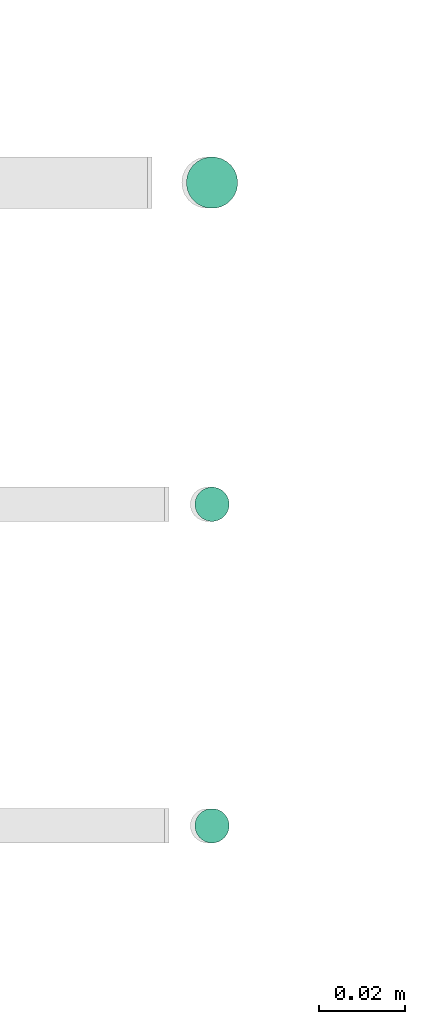
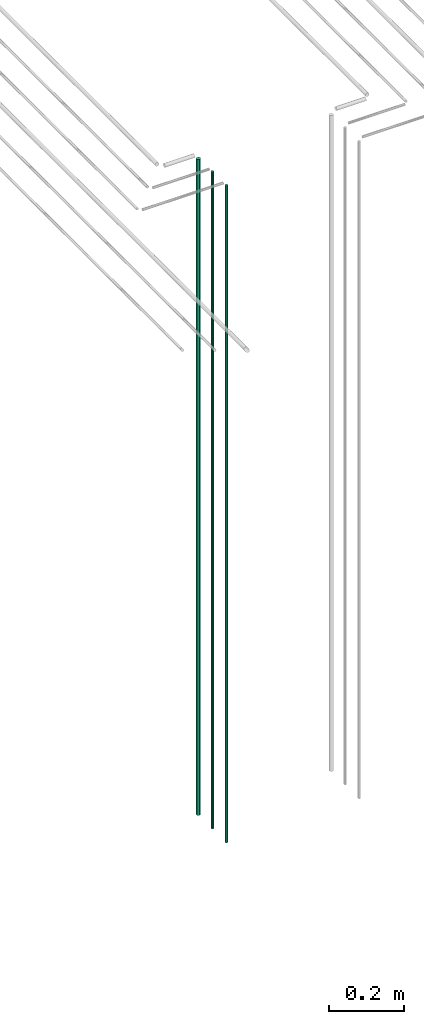
# One storey, part 56 of 331: 3 flow segments.
"""IFC2X3 building model written with IfcOpenShell, lengths in millimetres."""

from ifc_helpers import new_model, entity, si_unit, converted_unit, derived_unit, direction, frame, origin, origin_2d_with_axis, place, context, subcontext, project, spatial, circle, extrude, type_object, element, save


model = new_model("IFC2X3")

# Units and contexts
model_context = context("Model", 3, precision=0.01, world=origin(), true_north=direction((6.12303176911189e-17, 1.0)))
body_context = subcontext(model_context, "Body", "Model", "MODEL_VIEW")
ifc_project = project(units=[si_unit("LENGTHUNIT", "METRE", prefix="MILLI"), si_unit("AREAUNIT", "SQUARE_METRE"), si_unit("VOLUMEUNIT", "CUBIC_METRE"), converted_unit("PLANEANGLEUNIT", "DEGREE", entity("IfcRatioMeasure", 0.0174532925199433), si_unit("PLANEANGLEUNIT", "RADIAN"), dimensions=[0, 0, 0, 0, 0, 0, 0]), si_unit("MASSUNIT", "GRAM", prefix="KILO"), derived_unit("MASSDENSITYUNIT", [(si_unit("MASSUNIT", "GRAM", prefix="KILO"), 1), (si_unit("LENGTHUNIT", "METRE"), -3)]), derived_unit("MOMENTOFINERTIAUNIT", [(si_unit("LENGTHUNIT", "METRE"), 4)]), si_unit("TIMEUNIT", "SECOND"), si_unit("FREQUENCYUNIT", "HERTZ"), si_unit("THERMODYNAMICTEMPERATUREUNIT", "DEGREE_CELSIUS"), derived_unit("THERMALTRANSMITTANCEUNIT", [(si_unit("MASSUNIT", "GRAM", prefix="KILO"), 1), (si_unit("THERMODYNAMICTEMPERATUREUNIT", "KELVIN"), -1), (si_unit("TIMEUNIT", "SECOND"), -3)]), derived_unit("VOLUMETRICFLOWRATEUNIT", [(si_unit("LENGTHUNIT", "METRE"), 3), (si_unit("TIMEUNIT", "SECOND"), -1)]), derived_unit("MASSFLOWRATEUNIT", [(si_unit("MASSUNIT", "GRAM", prefix="KILO"), 1), (si_unit("TIMEUNIT", "SECOND"), -1)]), derived_unit("ROTATIONALFREQUENCYUNIT", [(si_unit("TIMEUNIT", "SECOND"), -1)]), si_unit("ELECTRICCURRENTUNIT", "AMPERE"), si_unit("ELECTRICVOLTAGEUNIT", "VOLT"), si_unit("POWERUNIT", "WATT"), si_unit("FORCEUNIT", "NEWTON", prefix="KILO"), si_unit("ILLUMINANCEUNIT", "LUX"), si_unit("LUMINOUSFLUXUNIT", "LUMEN"), si_unit("LUMINOUSINTENSITYUNIT", "CANDELA"), derived_unit("USERDEFINED", [(si_unit("MASSUNIT", "GRAM", prefix="KILO"), -1), (si_unit("LENGTHUNIT", "METRE"), -2), (si_unit("TIMEUNIT", "SECOND"), 3), (si_unit("LUMINOUSFLUXUNIT", "LUMEN"), 1)]), derived_unit("LINEARVELOCITYUNIT", [(si_unit("LENGTHUNIT", "METRE"), 1), (si_unit("TIMEUNIT", "SECOND"), -1)]), si_unit("PRESSUREUNIT", "PASCAL"), derived_unit("USERDEFINED", [(si_unit("LENGTHUNIT", "METRE"), -2), (si_unit("MASSUNIT", "GRAM", prefix="KILO"), 1), (si_unit("TIMEUNIT", "SECOND"), -2)]), derived_unit("LINEARFORCEUNIT", [(si_unit("MASSUNIT", "GRAM", prefix="KILO"), 1), (si_unit("LENGTHUNIT", "METRE"), 1), (si_unit("TIMEUNIT", "SECOND"), -2), (si_unit("LENGTHUNIT", "METRE"), -1)]), derived_unit("PLANARFORCEUNIT", [(si_unit("MASSUNIT", "GRAM", prefix="KILO"), 1), (si_unit("LENGTHUNIT", "METRE"), 1), (si_unit("TIMEUNIT", "SECOND"), -2), (si_unit("LENGTHUNIT", "METRE"), -2)])], contexts=[model_context])

# Site, building, storey
site_placement = place(None, frame((0.0, -0.00077364408347762, 0.0)))
site = spatial("IfcSite", under=ifc_project, at=site_placement, CompositionType="ELEMENT")
building_placement = place(site_placement, origin())
building = spatial("IfcBuilding", under=site, at=building_placement, CompositionType="ELEMENT")
storey_placement = place(building_placement, origin())
storey = spatial("IfcBuildingStorey", under=building, at=storey_placement, CompositionType="ELEMENT", Elevation=0.0)

# Flow segments
pipe_segment_type = type_object("IfcPipeSegmentType", PredefinedType="NOTDEFINED")
flow_segment_placement = place(storey_placement, frame((53157.8976593377, 3883.89349484365, 12990.0)))
element("IfcFlowSegment", 1, at=flow_segment_placement, inside=storey, type_object=pipe_segment_type, context=body_context, shape_type="SweptSolid", body=[
    extrude(circle(Radius=6.0, at=origin_2d_with_axis()), frame((7.59527223591454, 7.59527223591616, 0.0)), (0.0, 0.0, 1.0), 2146.0),
])
for number, where in (
    (2, (53159.8976593377, 3735.89349484359, 12990.0)),
    (3, (53159.8976593377, 3810.89349484379, 12990.0)),
):
    element("IfcFlowSegment", number, at=place(storey_placement, frame(where)), inside=storey, type_object=pipe_segment_type, context=body_context, shape_type="SweptSolid", body=[
        extrude(circle(Radius=4.0, at=origin_2d_with_axis()), frame((5.59527223591499, 5.59527223591607, 0.0)), (0.0, 0.0, 1.0), 2150.00000000001),
    ])

save(model, "model.ifc")
